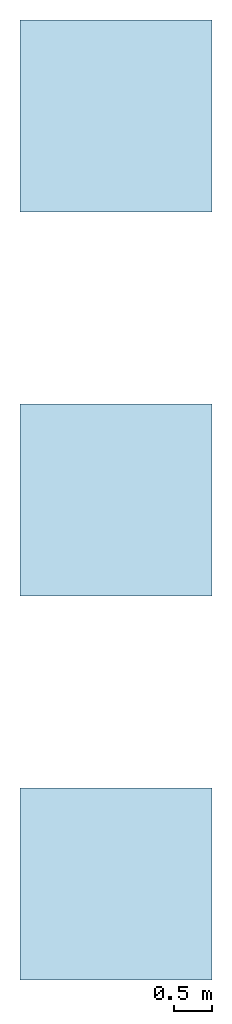
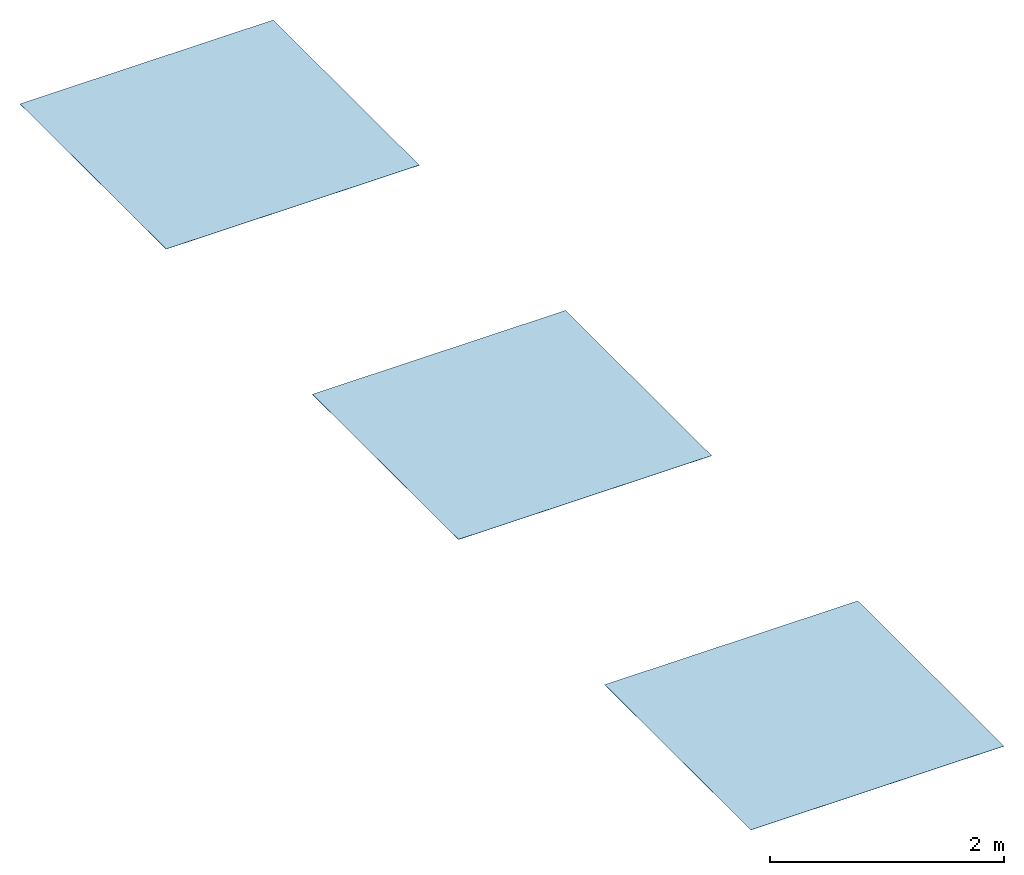
# Not in any storey: 3 slabs.
"""IFC2X3 building model written with IfcOpenShell, lengths in millimetres."""

from ifc_helpers import new_model, si_unit, frame, frame_2d, origin, origin_with_axes, origin_2d, place, context, project, spatial, rectangle, extrude, material, layer, layer_set, layer_usage, type_object, element, save


model = new_model("IFC2X3")

# Units and contexts
model_context = context("Model", 3, precision=1e-05, world=origin())
plan_context = context("Plan", 2, precision=1e-05, world=origin_2d())
ifc_project = project(units=[si_unit("LENGTHUNIT", "METRE", prefix="MILLI"), si_unit("AREAUNIT", "SQUARE_METRE"), si_unit("VOLUMEUNIT", "CUBIC_METRE"), si_unit("SOLIDANGLEUNIT", "STERADIAN"), si_unit("PLANEANGLEUNIT", "RADIAN"), si_unit("MASSUNIT", "GRAM"), si_unit("TIMEUNIT", "SECOND"), si_unit("THERMODYNAMICTEMPERATUREUNIT", "DEGREE_CELSIUS"), si_unit("LUMINOUSINTENSITYUNIT", "LUMEN")], contexts=[model_context, plan_context])

# Site, building
site_placement = place(None, frame((0.0, 0.0, 0.0), z_axis=(0.0, 1.0, 0.0), x_axis=(0.0, 0.0, 1.0)))
site = spatial("IfcSite", under=ifc_project, at=site_placement, CompositionType="ELEMENT")
building_placement = place(site_placement, frame((0.0, 0.0, 0.0), z_axis=(0.0, 1.0, 0.0), x_axis=(0.0, 0.0, 1.0)))
building = spatial("IfcBuilding", under=site, at=building_placement, Name="Default building", CompositionType="ELEMENT")

# Slabs
ifc_material_1 = material()
ifc_layer_1 = layer(ifc_material_1, 2.0, ventilated=False)
ifc_layer_set_1 = layer_set([ifc_layer_1])
ifc_layer_usage_1 = layer_usage(ifc_layer_set_1, "AXIS3", "NEGATIVE", 0.0)
slab_type_1 = type_object("IfcSlabType", PredefinedType="ROOF", material=ifc_layer_set_1)
slab_1_placement = place(None, origin())
element("IfcSlab", 1, at=slab_1_placement, inside=building, type_object=slab_type_1, material=ifc_layer_usage_1, PredefinedType="ROOF", context=model_context, shape_type="SweptSolid", body=[
    extrude(rectangle(XDim=2500.0, YDim=2500.0, at=frame_2d((1250.0, 1250.0))), origin_with_axes(), (0.0, 0.0, 1.0), 2.0),
])
ifc_material_2 = material()
ifc_layer_2 = layer(ifc_material_2, 2.0, ventilated=False)
ifc_layer_set_2 = layer_set([ifc_layer_2])
ifc_layer_usage_2 = layer_usage(ifc_layer_set_2, "AXIS3", "NEGATIVE", 0.0)
slab_type_2 = type_object("IfcSlabType", PredefinedType="ROOF", material=ifc_layer_set_2)
slab_2_placement = place(None, frame((0.0, 5000.0, 0.0)))
element("IfcSlab", 2, at=slab_2_placement, inside=building, type_object=slab_type_2, material=ifc_layer_usage_2, PredefinedType="ROOF", context=model_context, shape_type="SweptSolid", body=[
    extrude(rectangle(XDim=2500.0, YDim=2500.0, at=frame_2d((1250.0, 1250.0))), origin_with_axes(), (0.0, 0.0, 1.0), 2.0),
])
ifc_material_3 = material()
ifc_layer_3 = layer(ifc_material_3, 2.0, ventilated=False)
ifc_layer_set_3 = layer_set([ifc_layer_3])
ifc_layer_usage_3 = layer_usage(ifc_layer_set_3, "AXIS3", "NEGATIVE", 0.0)
slab_type_3 = type_object("IfcSlabType", PredefinedType="ROOF", material=ifc_layer_set_3)
slab_3_placement = place(None, frame((0.0, 10000.0, 0.0)))
element("IfcSlab", 3, at=slab_3_placement, inside=building, type_object=slab_type_3, material=ifc_layer_usage_3, PredefinedType="ROOF", context=model_context, shape_type="SweptSolid", body=[
    extrude(rectangle(XDim=2500.0, YDim=2500.0, at=frame_2d((1250.0, 1250.0))), origin_with_axes(), (0.0, 0.0, 1.0), 2.0),
])

save(model, "model.ifc")
